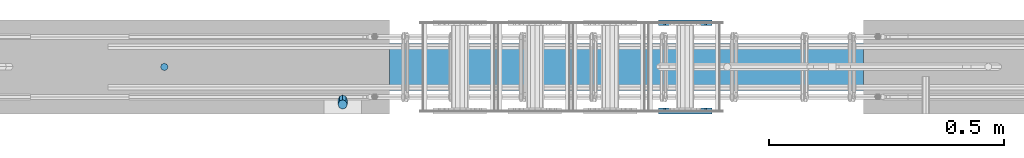
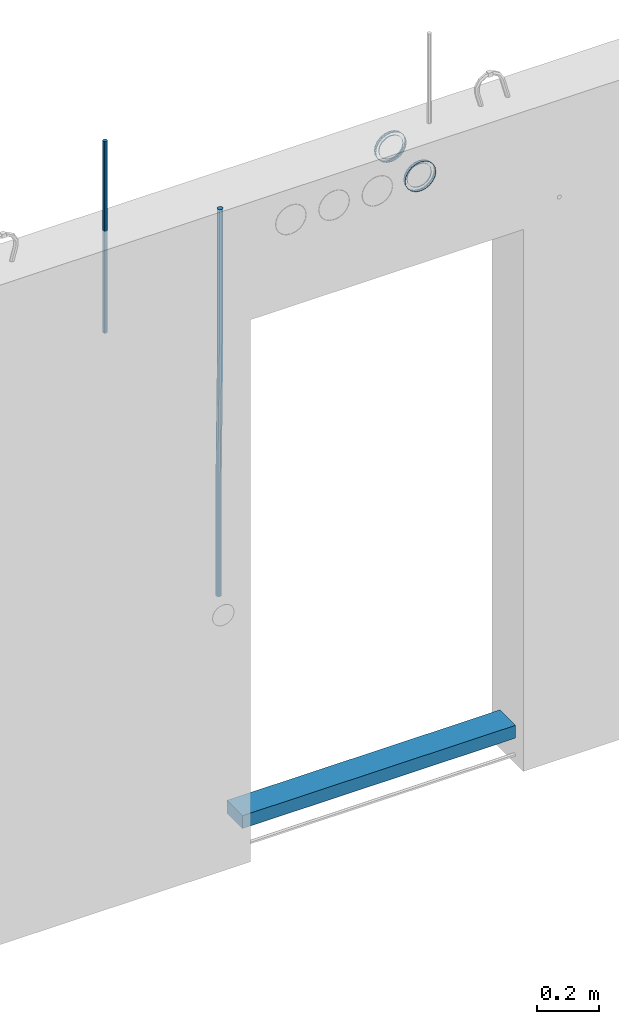
# One storey, part 1 of 11: 9 beams.
"""IFC2X3 building model written with IfcOpenShell, lengths in millimetres."""

from ifc_helpers import new_model, si_unit, frame, origin_with_axes, place, context, subcontext, project, spatial, faceted_brep, material, type_object, element, save


model = new_model("IFC2X3")

# Units and contexts
model_context = context("Model", 3, precision=1e-05, world=origin_with_axes())
body_context = subcontext(model_context, "Body", "Model", "MODEL_VIEW")
ifc_project = project(units=[si_unit("LENGTHUNIT", "METRE", prefix="MILLI"), si_unit("AREAUNIT", "SQUARE_METRE"), si_unit("VOLUMEUNIT", "CUBIC_METRE"), si_unit("MASSUNIT", "GRAM", prefix="KILO"), si_unit("TIMEUNIT", "SECOND"), si_unit("PLANEANGLEUNIT", "RADIAN"), si_unit("SOLIDANGLEUNIT", "STERADIAN"), si_unit("THERMODYNAMICTEMPERATUREUNIT", "DEGREE_CELSIUS"), si_unit("LUMINOUSINTENSITYUNIT", "LUMEN")], contexts=[model_context])

# Site, building, storey
site_placement = place(None, origin_with_axes())
site = spatial("IfcSite", under=ifc_project, at=site_placement, CompositionType="ELEMENT")
building_placement = place(site_placement, origin_with_axes())
building = spatial("IfcBuilding", under=site, at=building_placement, Name="Undefined", CompositionType="ELEMENT")
storey_placement = place(building_placement, origin_with_axes())
storey = spatial("IfcBuildingStorey", under=building, at=storey_placement, Name="Undefined", CompositionType="ELEMENT", Elevation=0.0)

# Beams
ifc_material_1 = material(Name="REBAR/A500HW")
beam_type_1 = type_object("IfcBeamType", Name="D16", PredefinedType="NOTDEFINED")
beam_1_placement = place(storey_placement, frame((869.990014805153, -99.9999587567853, 2805.000000041), z_axis=(-1.0, 0.0, 0.0), x_axis=(0.0, 0.0, -1.0)))
element("IfcBeam", 1, at=beam_1_placement, inside=storey, type_object=beam_type_1, material=ifc_material_1, ObjectType="D16", context=body_context, shape_type="Brep", body=[
    faceted_brep([(0.0, -8.0, 0.0), (0.0, -5.65685424949238, -5.65685424949243), (750.0, -5.65685424949238, -5.65685424949243), (750.0, -8.0, 0.0), (0.0, 0.0, -8.0), (750.0, 0.0, -8.0), (0.0, 5.65685424949238, -5.65685424949243), (750.0, 5.65685424949238, -5.65685424949243), (0.0, 8.0, 0.0), (750.0, 8.0, 0.0), (0.0, 5.65685424949238, 5.65685424949243), (750.0, 5.65685424949238, 5.65685424949243), (0.0, 0.0, 8.0), (750.0, 0.0, 8.0), (0.0, -5.65685424949238, 5.65685424949243), (750.0, -5.65685424949238, 5.65685424949243)], [[[0, 1, 2, 3]], [[1, 4, 5, 2]], [[4, 6, 7, 5]], [[6, 8, 9, 7]], [[8, 10, 11, 9]], [[10, 12, 13, 11]], [[12, 14, 15, 13]], [[14, 0, 3, 15]], [[5, 7, 9, 11, 13, 15, 3, 2]], [[14, 12, 10, 8, 6, 4, 1, 0]]]),
])
ifc_material_2 = material(Name="TIMBER")
beam_type_2 = type_object("IfcBeamType", Name="50X100", PredefinedType="NOTDEFINED")
beam_2_placement = place(storey_placement, frame((1349.99888029706, -99.9999994195658, 4.10316260968102e-08), z_axis=(0.0, 0.0, 1.0), x_axis=(1.0, 0.0, 0.0)))
element("IfcBeam", 2, at=beam_2_placement, inside=storey, type_object=beam_type_2, material=ifc_material_2, ObjectType="50X100", context=body_context, shape_type="Brep", body=[
    faceted_brep([(0.0, 50.0, -25.0), (0.0, 50.0, 25.0), (1010.00203523022, 50.0, 25.0), (1010.00203523022, 50.0, -25.0), (0.0, -50.0, 25.0), (1010.00203523022, -50.0, 25.0), (0.0, -50.0, -25.0), (1010.00203523022, -50.0, -25.0)], [[[0, 1, 2, 3]], [[1, 4, 5, 2]], [[4, 6, 7, 5]], [[6, 0, 3, 7]], [[5, 7, 3, 2]], [[6, 4, 1, 0]]]),
])
ifc_material_3 = material(Name="STEEL/Steel_Undefined")
beam_type_3 = type_object("IfcBeamType", PredefinedType="NOTDEFINED")
beam_3_placement = place(storey_placement, frame((1979.98457749309, -5.08317012009296, 2335.01381840039), z_axis=(-1.0, 0.0, 0.0), x_axis=(0.0, 1.0, 0.0)))
element("IfcBeam", 3, at=beam_3_placement, inside=storey, type_object=beam_type_3, material=ifc_material_3, Name="K160", context=body_context, shape_type="Brep", body=[
    faceted_brep([(0.0, -56.0, 0.0), (0.0, -53.2591649125284, 17.3049516849972), (5.0, -53.2591649125284, 17.3049516849972), (5.0, -56.0, 0.0), (0.0, -45.3049516849969, 32.9159741283786), (5.0, -45.3049516849969, 32.9159741283786), (0.0, -32.9159741283784, 45.3049516849972), (5.0, -32.9159741283784, 45.3049516849972), (0.0, -17.3049516849969, 53.2591649125286), (5.0, -17.3049516849969, 53.2591649125286), (0.0, 0.0, 56.0), (5.0, 0.0, 56.0), (0.0, 17.3049516849969, 53.2591649125286), (5.0, 17.3049516849969, 53.2591649125286), (0.0, 32.9159741283784, 45.3049516849972), (5.0, 32.9159741283784, 45.3049516849972), (0.0, 45.3049516849969, 32.9159741283786), (5.0, 45.3049516849969, 32.9159741283786), (0.0, 53.2591649125284, 17.3049516849972), (5.0, 53.2591649125284, 17.3049516849972), (0.0, 56.0, 0.0), (5.0, 56.0, 0.0), (0.0, 53.2591649125284, -17.3049516849972), (5.0, 53.2591649125284, -17.3049516849972), (0.0, 45.3049516849969, -32.9159741283786), (5.0, 45.3049516849969, -32.9159741283786), (0.0, 32.9159741283784, -45.3049516849972), (5.0, 32.9159741283784, -45.3049516849972), (0.0, 17.3049516849969, -53.2591649125286), (5.0, 17.3049516849969, -53.2591649125286), (0.0, 0.0, -56.0), (5.0, 0.0, -56.0), (0.0, -17.3049516849969, -53.2591649125286), (5.0, -17.3049516849969, -53.2591649125286), (0.0, -32.9159741283784, -45.3049516849972), (5.0, -32.9159741283784, -45.3049516849972), (0.0, -45.3049516849969, -32.9159741283786), (5.0, -45.3049516849969, -32.9159741283786), (0.0, -53.2591649125284, -17.3049516849972), (5.0, -53.2591649125284, -17.3049516849972), (0.0, -57.0, 0.0), (0.0, -54.2102214288238, -17.613968679372), (5.0, -54.2102214288238, -17.613968679372), (5.0, -57.0, 0.0), (0.0, -46.1139686793722, -33.503759380671), (5.0, -46.1139686793722, -33.503759380671), (0.0, -33.503759380671, -46.113968679372), (5.0, -33.503759380671, -46.113968679372), (0.0, -17.6139686793722, -54.2102214288238), (5.0, -17.6139686793722, -54.2102214288238), (0.0, 0.0, -57.0), (5.0, 0.0, -57.0), (0.0, 17.6139686793722, -54.2102214288238), (5.0, 17.6139686793722, -54.2102214288238), (0.0, 33.503759380671, -46.113968679372), (5.0, 33.503759380671, -46.113968679372), (0.0, 46.1139686793722, -33.503759380671), (5.0, 46.1139686793722, -33.503759380671), (0.0, 54.2102214288238, -17.613968679372), (5.0, 54.2102214288238, -17.613968679372), (0.0, 57.0, 0.0), (5.0, 57.0, 0.0), (0.0, 54.2102214288238, 17.613968679372), (5.0, 54.2102214288238, 17.613968679372), (0.0, 46.1139686793722, 33.503759380671), (5.0, 46.1139686793722, 33.503759380671), (0.0, 33.503759380671, 46.113968679372), (5.0, 33.503759380671, 46.113968679372), (0.0, 17.6139686793722, 54.2102214288238), (5.0, 17.6139686793722, 54.2102214288238), (0.0, 0.0, 57.0), (5.0, 0.0, 57.0), (0.0, -17.6139686793722, 54.2102214288238), (5.0, -17.6139686793722, 54.2102214288238), (0.0, -33.503759380671, 46.113968679372), (5.0, -33.503759380671, 46.113968679372), (0.0, -46.1139686793722, 33.503759380671), (5.0, -46.1139686793722, 33.503759380671), (0.0, -54.2102214288238, 17.613968679372), (5.0, -54.2102214288238, 17.613968679372)], [[[0, 1, 2, 3]], [[1, 4, 5, 2]], [[4, 6, 7, 5]], [[6, 8, 9, 7]], [[8, 10, 11, 9]], [[10, 12, 13, 11]], [[12, 14, 15, 13]], [[14, 16, 17, 15]], [[16, 18, 19, 17]], [[18, 20, 21, 19]], [[20, 22, 23, 21]], [[22, 24, 25, 23]], [[24, 26, 27, 25]], [[26, 28, 29, 27]], [[28, 30, 31, 29]], [[30, 32, 33, 31]], [[32, 34, 35, 33]], [[34, 36, 37, 35]], [[36, 38, 39, 37]], [[38, 0, 3, 39]], [[40, 41, 42, 43]], [[41, 44, 45, 42]], [[44, 46, 47, 45]], [[46, 48, 49, 47]], [[48, 50, 51, 49]], [[50, 52, 53, 51]], [[52, 54, 55, 53]], [[54, 56, 57, 55]], [[56, 58, 59, 57]], [[58, 60, 61, 59]], [[60, 62, 63, 61]], [[62, 64, 65, 63]], [[64, 66, 67, 65]], [[66, 68, 69, 67]], [[68, 70, 71, 69]], [[70, 72, 73, 71]], [[72, 74, 75, 73]], [[74, 76, 77, 75]], [[76, 78, 79, 77]], [[78, 40, 43, 79]], [[45, 47, 49, 51, 53, 55, 57, 59, 61, 63, 65, 67, 69, 71, 73, 75, 77, 79, 43, 42], [5, 7, 9, 11, 13, 15, 17, 19, 21, 23, 25, 27, 29, 31, 33, 35, 37, 39, 3, 2]], [[78, 76, 74, 72, 70, 68, 66, 64, 62, 60, 58, 56, 54, 52, 50, 48, 46, 44, 41, 40], [38, 36, 34, 32, 30, 28, 26, 24, 22, 20, 18, 16, 14, 12, 10, 8, 6, 4, 1, 0]]]),
])
beam_4_placement = place(storey_placement, frame((1979.98457749309, -200.083170120093, 2335.01381840039), z_axis=(-1.0, 0.0, 0.0), x_axis=(0.0, 1.0, 0.0)))
element("IfcBeam", 4, at=beam_4_placement, inside=storey, type_object=beam_type_3, material=ifc_material_3, context=body_context, shape_type="Brep", body=[
    faceted_brep([(0.0, -56.0, 0.0), (0.0, -53.2591649125284, 17.3049516849972), (5.0, -53.2591649125284, 17.3049516849972), (5.0, -56.0, 0.0), (0.0, -45.3049516849969, 32.9159741283786), (5.0, -45.3049516849969, 32.9159741283786), (0.0, -32.9159741283784, 45.3049516849972), (5.0, -32.9159741283784, 45.3049516849972), (0.0, -17.3049516849969, 53.2591649125286), (5.0, -17.3049516849969, 53.2591649125286), (0.0, 0.0, 56.0), (5.0, 0.0, 56.0), (0.0, 17.3049516849969, 53.2591649125286), (5.0, 17.3049516849969, 53.2591649125286), (0.0, 32.9159741283784, 45.3049516849972), (5.0, 32.9159741283784, 45.3049516849972), (0.0, 45.3049516849969, 32.9159741283786), (5.0, 45.3049516849969, 32.9159741283786), (0.0, 53.2591649125284, 17.3049516849972), (5.0, 53.2591649125284, 17.3049516849972), (0.0, 56.0, 0.0), (5.0, 56.0, 0.0), (0.0, 53.2591649125284, -17.3049516849972), (5.0, 53.2591649125284, -17.3049516849972), (0.0, 45.3049516849969, -32.9159741283786), (5.0, 45.3049516849969, -32.9159741283786), (0.0, 32.9159741283784, -45.3049516849972), (5.0, 32.9159741283784, -45.3049516849972), (0.0, 17.3049516849969, -53.2591649125286), (5.0, 17.3049516849969, -53.2591649125286), (0.0, 0.0, -56.0), (5.0, 0.0, -56.0), (0.0, -17.3049516849969, -53.2591649125286), (5.0, -17.3049516849969, -53.2591649125286), (0.0, -32.9159741283784, -45.3049516849972), (5.0, -32.9159741283784, -45.3049516849972), (0.0, -45.3049516849969, -32.9159741283786), (5.0, -45.3049516849969, -32.9159741283786), (0.0, -53.2591649125284, -17.3049516849972), (5.0, -53.2591649125284, -17.3049516849972), (0.0, -57.0, 0.0), (0.0, -54.2102214288238, -17.613968679372), (5.0, -54.2102214288238, -17.613968679372), (5.0, -57.0, 0.0), (0.0, -46.1139686793722, -33.503759380671), (5.0, -46.1139686793722, -33.503759380671), (0.0, -33.503759380671, -46.113968679372), (5.0, -33.503759380671, -46.113968679372), (0.0, -17.6139686793722, -54.2102214288238), (5.0, -17.6139686793722, -54.2102214288238), (0.0, 0.0, -57.0), (5.0, 0.0, -57.0), (0.0, 17.6139686793722, -54.2102214288238), (5.0, 17.6139686793722, -54.2102214288238), (0.0, 33.503759380671, -46.113968679372), (5.0, 33.503759380671, -46.113968679372), (0.0, 46.1139686793722, -33.503759380671), (5.0, 46.1139686793722, -33.503759380671), (0.0, 54.2102214288238, -17.613968679372), (5.0, 54.2102214288238, -17.613968679372), (0.0, 57.0, 0.0), (5.0, 57.0, 0.0), (0.0, 54.2102214288238, 17.613968679372), (5.0, 54.2102214288238, 17.613968679372), (0.0, 46.1139686793722, 33.503759380671), (5.0, 46.1139686793722, 33.503759380671), (0.0, 33.503759380671, 46.113968679372), (5.0, 33.503759380671, 46.113968679372), (0.0, 17.6139686793722, 54.2102214288238), (5.0, 17.6139686793722, 54.2102214288238), (0.0, 0.0, 57.0), (5.0, 0.0, 57.0), (0.0, -17.6139686793722, 54.2102214288238), (5.0, -17.6139686793722, 54.2102214288238), (0.0, -33.503759380671, 46.113968679372), (5.0, -33.503759380671, 46.113968679372), (0.0, -46.1139686793722, 33.503759380671), (5.0, -46.1139686793722, 33.503759380671), (0.0, -54.2102214288238, 17.613968679372), (5.0, -54.2102214288238, 17.613968679372)], [[[0, 1, 2, 3]], [[1, 4, 5, 2]], [[4, 6, 7, 5]], [[6, 8, 9, 7]], [[8, 10, 11, 9]], [[10, 12, 13, 11]], [[12, 14, 15, 13]], [[14, 16, 17, 15]], [[16, 18, 19, 17]], [[18, 20, 21, 19]], [[20, 22, 23, 21]], [[22, 24, 25, 23]], [[24, 26, 27, 25]], [[26, 28, 29, 27]], [[28, 30, 31, 29]], [[30, 32, 33, 31]], [[32, 34, 35, 33]], [[34, 36, 37, 35]], [[36, 38, 39, 37]], [[38, 0, 3, 39]], [[40, 41, 42, 43]], [[41, 44, 45, 42]], [[44, 46, 47, 45]], [[46, 48, 49, 47]], [[48, 50, 51, 49]], [[50, 52, 53, 51]], [[52, 54, 55, 53]], [[54, 56, 57, 55]], [[56, 58, 59, 57]], [[58, 60, 61, 59]], [[60, 62, 63, 61]], [[62, 64, 65, 63]], [[64, 66, 67, 65]], [[66, 68, 69, 67]], [[68, 70, 71, 69]], [[70, 72, 73, 71]], [[72, 74, 75, 73]], [[74, 76, 77, 75]], [[76, 78, 79, 77]], [[78, 40, 43, 79]], [[45, 47, 49, 51, 53, 55, 57, 59, 61, 63, 65, 67, 69, 71, 73, 75, 77, 79, 43, 42], [5, 7, 9, 11, 13, 15, 17, 19, 21, 23, 25, 27, 29, 31, 33, 35, 37, 39, 3, 2]], [[78, 76, 74, 72, 70, 68, 66, 64, 62, 60, 58, 56, 54, 52, 50, 48, 46, 44, 41, 40], [38, 36, 34, 32, 30, 28, 26, 24, 22, 20, 18, 16, 14, 12, 10, 8, 6, 4, 1, 0]]]),
])
beam_5_placement = place(storey_placement, frame((1979.98457749309, -12.083170120093, 2335.01381840039), z_axis=(-1.0, 0.0, 0.0), x_axis=(0.0, 1.0, 0.0)))
element("IfcBeam", 5, at=beam_5_placement, inside=storey, type_object=beam_type_3, material=ifc_material_3, context=body_context, shape_type="Brep", body=[
    faceted_brep([(0.0, -56.0, 0.0), (0.0, -53.2591649125284, 17.3049516849972), (5.0, -53.2591649125284, 17.3049516849972), (5.0, -56.0, 0.0), (0.0, -45.3049516849969, 32.9159741283786), (5.0, -45.3049516849969, 32.9159741283786), (0.0, -32.9159741283784, 45.3049516849972), (5.0, -32.9159741283784, 45.3049516849972), (0.0, -17.3049516849969, 53.2591649125286), (5.0, -17.3049516849969, 53.2591649125286), (0.0, 0.0, 56.0), (5.0, 0.0, 56.0), (0.0, 17.3049516849969, 53.2591649125286), (5.0, 17.3049516849969, 53.2591649125286), (0.0, 32.9159741283784, 45.3049516849972), (5.0, 32.9159741283784, 45.3049516849972), (0.0, 45.3049516849969, 32.9159741283786), (5.0, 45.3049516849969, 32.9159741283786), (0.0, 53.2591649125284, 17.3049516849972), (5.0, 53.2591649125284, 17.3049516849972), (0.0, 56.0, 0.0), (5.0, 56.0, 0.0), (0.0, 53.2591649125284, -17.3049516849972), (5.0, 53.2591649125284, -17.3049516849972), (0.0, 45.3049516849969, -32.9159741283786), (5.0, 45.3049516849969, -32.9159741283786), (0.0, 32.9159741283784, -45.3049516849972), (5.0, 32.9159741283784, -45.3049516849972), (0.0, 17.3049516849969, -53.2591649125286), (5.0, 17.3049516849969, -53.2591649125286), (0.0, 0.0, -56.0), (5.0, 0.0, -56.0), (0.0, -17.3049516849969, -53.2591649125286), (5.0, -17.3049516849969, -53.2591649125286), (0.0, -32.9159741283784, -45.3049516849972), (5.0, -32.9159741283784, -45.3049516849972), (0.0, -45.3049516849969, -32.9159741283786), (5.0, -45.3049516849969, -32.9159741283786), (0.0, -53.2591649125284, -17.3049516849972), (5.0, -53.2591649125284, -17.3049516849972), (0.0, -57.0, 0.0), (0.0, -54.2102214288238, -17.613968679372), (5.0, -54.2102214288238, -17.613968679372), (5.0, -57.0, 0.0), (0.0, -46.1139686793722, -33.503759380671), (5.0, -46.1139686793722, -33.503759380671), (0.0, -33.503759380671, -46.113968679372), (5.0, -33.503759380671, -46.113968679372), (0.0, -17.6139686793722, -54.2102214288238), (5.0, -17.6139686793722, -54.2102214288238), (0.0, 0.0, -57.0), (5.0, 0.0, -57.0), (0.0, 17.6139686793722, -54.2102214288238), (5.0, 17.6139686793722, -54.2102214288238), (0.0, 33.503759380671, -46.113968679372), (5.0, 33.503759380671, -46.113968679372), (0.0, 46.1139686793722, -33.503759380671), (5.0, 46.1139686793722, -33.503759380671), (0.0, 54.2102214288238, -17.613968679372), (5.0, 54.2102214288238, -17.613968679372), (0.0, 57.0, 0.0), (5.0, 57.0, 0.0), (0.0, 54.2102214288238, 17.613968679372), (5.0, 54.2102214288238, 17.613968679372), (0.0, 46.1139686793722, 33.503759380671), (5.0, 46.1139686793722, 33.503759380671), (0.0, 33.503759380671, 46.113968679372), (5.0, 33.503759380671, 46.113968679372), (0.0, 17.6139686793722, 54.2102214288238), (5.0, 17.6139686793722, 54.2102214288238), (0.0, 0.0, 57.0), (5.0, 0.0, 57.0), (0.0, -17.6139686793722, 54.2102214288238), (5.0, -17.6139686793722, 54.2102214288238), (0.0, -33.503759380671, 46.113968679372), (5.0, -33.503759380671, 46.113968679372), (0.0, -46.1139686793722, 33.503759380671), (5.0, -46.1139686793722, 33.503759380671), (0.0, -54.2102214288238, 17.613968679372), (5.0, -54.2102214288238, 17.613968679372)], [[[0, 1, 2, 3]], [[1, 4, 5, 2]], [[4, 6, 7, 5]], [[6, 8, 9, 7]], [[8, 10, 11, 9]], [[10, 12, 13, 11]], [[12, 14, 15, 13]], [[14, 16, 17, 15]], [[16, 18, 19, 17]], [[18, 20, 21, 19]], [[20, 22, 23, 21]], [[22, 24, 25, 23]], [[24, 26, 27, 25]], [[26, 28, 29, 27]], [[28, 30, 31, 29]], [[30, 32, 33, 31]], [[32, 34, 35, 33]], [[34, 36, 37, 35]], [[36, 38, 39, 37]], [[38, 0, 3, 39]], [[40, 41, 42, 43]], [[41, 44, 45, 42]], [[44, 46, 47, 45]], [[46, 48, 49, 47]], [[48, 50, 51, 49]], [[50, 52, 53, 51]], [[52, 54, 55, 53]], [[54, 56, 57, 55]], [[56, 58, 59, 57]], [[58, 60, 61, 59]], [[60, 62, 63, 61]], [[62, 64, 65, 63]], [[64, 66, 67, 65]], [[66, 68, 69, 67]], [[68, 70, 71, 69]], [[70, 72, 73, 71]], [[72, 74, 75, 73]], [[74, 76, 77, 75]], [[76, 78, 79, 77]], [[78, 40, 43, 79]], [[45, 47, 49, 51, 53, 55, 57, 59, 61, 63, 65, 67, 69, 71, 73, 75, 77, 79, 43, 42], [5, 7, 9, 11, 13, 15, 17, 19, 21, 23, 25, 27, 29, 31, 33, 35, 37, 39, 3, 2]], [[78, 76, 74, 72, 70, 68, 66, 64, 62, 60, 58, 56, 54, 52, 50, 48, 46, 44, 41, 40], [38, 36, 34, 32, 30, 28, 26, 24, 22, 20, 18, 16, 14, 12, 10, 8, 6, 4, 1, 0]]]),
])
beam_6_placement = place(storey_placement, frame((1979.98457749309, -188.083170120093, 2335.01381840039), z_axis=(-1.0, 0.0, 0.0), x_axis=(0.0, -1.0, 0.0)))
element("IfcBeam", 6, at=beam_6_placement, inside=storey, type_object=beam_type_3, material=ifc_material_3, context=body_context, shape_type="Brep", body=[
    faceted_brep([(0.0, -56.0, 0.0), (0.0, -53.2591649125284, 17.3049516849972), (5.0, -53.2591649125284, 17.3049516849972), (5.0, -56.0, 0.0), (0.0, -45.3049516849969, 32.9159741283786), (5.0, -45.3049516849969, 32.9159741283786), (0.0, -32.9159741283784, 45.3049516849972), (5.0, -32.9159741283784, 45.3049516849972), (0.0, -17.3049516849969, 53.2591649125286), (5.0, -17.3049516849969, 53.2591649125286), (0.0, 0.0, 56.0), (5.0, 0.0, 56.0), (0.0, 17.3049516849969, 53.2591649125286), (5.0, 17.3049516849969, 53.2591649125286), (0.0, 32.9159741283784, 45.3049516849972), (5.0, 32.9159741283784, 45.3049516849972), (0.0, 45.3049516849969, 32.9159741283786), (5.0, 45.3049516849969, 32.9159741283786), (0.0, 53.2591649125284, 17.3049516849972), (5.0, 53.2591649125284, 17.3049516849972), (0.0, 56.0, 0.0), (5.0, 56.0, 0.0), (0.0, 53.2591649125284, -17.3049516849972), (5.0, 53.2591649125284, -17.3049516849972), (0.0, 45.3049516849969, -32.9159741283786), (5.0, 45.3049516849969, -32.9159741283786), (0.0, 32.9159741283784, -45.3049516849972), (5.0, 32.9159741283784, -45.3049516849972), (0.0, 17.3049516849969, -53.2591649125286), (5.0, 17.3049516849969, -53.2591649125286), (0.0, 0.0, -56.0), (5.0, 0.0, -56.0), (0.0, -17.3049516849969, -53.2591649125286), (5.0, -17.3049516849969, -53.2591649125286), (0.0, -32.9159741283784, -45.3049516849972), (5.0, -32.9159741283784, -45.3049516849972), (0.0, -45.3049516849969, -32.9159741283786), (5.0, -45.3049516849969, -32.9159741283786), (0.0, -53.2591649125284, -17.3049516849972), (5.0, -53.2591649125284, -17.3049516849972), (0.0, -57.0, 0.0), (0.0, -54.2102214288238, -17.613968679372), (5.0, -54.2102214288238, -17.613968679372), (5.0, -57.0, 0.0), (0.0, -46.1139686793722, -33.503759380671), (5.0, -46.1139686793722, -33.503759380671), (0.0, -33.503759380671, -46.113968679372), (5.0, -33.503759380671, -46.113968679372), (0.0, -17.6139686793722, -54.2102214288238), (5.0, -17.6139686793722, -54.2102214288238), (0.0, 0.0, -57.0), (5.0, 0.0, -57.0), (0.0, 17.6139686793722, -54.2102214288238), (5.0, 17.6139686793722, -54.2102214288238), (0.0, 33.503759380671, -46.113968679372), (5.0, 33.503759380671, -46.113968679372), (0.0, 46.1139686793722, -33.503759380671), (5.0, 46.1139686793722, -33.503759380671), (0.0, 54.2102214288238, -17.613968679372), (5.0, 54.2102214288238, -17.613968679372), (0.0, 57.0, 0.0), (5.0, 57.0, 0.0), (0.0, 54.2102214288238, 17.613968679372), (5.0, 54.2102214288238, 17.613968679372), (0.0, 46.1139686793722, 33.503759380671), (5.0, 46.1139686793722, 33.503759380671), (0.0, 33.503759380671, 46.113968679372), (5.0, 33.503759380671, 46.113968679372), (0.0, 17.6139686793722, 54.2102214288238), (5.0, 17.6139686793722, 54.2102214288238), (0.0, 0.0, 57.0), (5.0, 0.0, 57.0), (0.0, -17.6139686793722, 54.2102214288238), (5.0, -17.6139686793722, 54.2102214288238), (0.0, -33.503759380671, 46.113968679372), (5.0, -33.503759380671, 46.113968679372), (0.0, -46.1139686793722, 33.503759380671), (5.0, -46.1139686793722, 33.503759380671), (0.0, -54.2102214288238, 17.613968679372), (5.0, -54.2102214288238, 17.613968679372)], [[[0, 1, 2, 3]], [[1, 4, 5, 2]], [[4, 6, 7, 5]], [[6, 8, 9, 7]], [[8, 10, 11, 9]], [[10, 12, 13, 11]], [[12, 14, 15, 13]], [[14, 16, 17, 15]], [[16, 18, 19, 17]], [[18, 20, 21, 19]], [[20, 22, 23, 21]], [[22, 24, 25, 23]], [[24, 26, 27, 25]], [[26, 28, 29, 27]], [[28, 30, 31, 29]], [[30, 32, 33, 31]], [[32, 34, 35, 33]], [[34, 36, 37, 35]], [[36, 38, 39, 37]], [[38, 0, 3, 39]], [[40, 41, 42, 43]], [[41, 44, 45, 42]], [[44, 46, 47, 45]], [[46, 48, 49, 47]], [[48, 50, 51, 49]], [[50, 52, 53, 51]], [[52, 54, 55, 53]], [[54, 56, 57, 55]], [[56, 58, 59, 57]], [[58, 60, 61, 59]], [[60, 62, 63, 61]], [[62, 64, 65, 63]], [[64, 66, 67, 65]], [[66, 68, 69, 67]], [[68, 70, 71, 69]], [[70, 72, 73, 71]], [[72, 74, 75, 73]], [[74, 76, 77, 75]], [[76, 78, 79, 77]], [[78, 40, 43, 79]], [[45, 47, 49, 51, 53, 55, 57, 59, 61, 63, 65, 67, 69, 71, 73, 75, 77, 79, 43, 42], [5, 7, 9, 11, 13, 15, 17, 19, 21, 23, 25, 27, 29, 31, 33, 35, 37, 39, 3, 2]], [[78, 76, 74, 72, 70, 68, 66, 64, 62, 60, 58, 56, 54, 52, 50, 48, 46, 44, 41, 40], [38, 36, 34, 32, 30, 28, 26, 24, 22, 20, 18, 16, 14, 12, 10, 8, 6, 4, 1, 0]]]),
])
beam_type_4 = type_object("IfcBeamType", PredefinedType="NOTDEFINED")
beam_7_placement = place(storey_placement, frame((1979.98457749309, -12.083170120093, 2335.01381840039), z_axis=(-1.0, 0.0, 0.0), x_axis=(0.0, 1.0, 0.0)))
element("IfcBeam", 7, at=beam_7_placement, inside=storey, type_object=beam_type_4, material=ifc_material_3, context=body_context, shape_type="Brep", body=[
    faceted_brep([(0.0, -44.5, 0.0), (0.0, -41.1126391967523, 17.0294127402465), (5.0, -41.1126391967523, 17.0294127402465), (5.0, -44.5, 0.0), (0.0, -31.4662517628012, 31.4662517628014), (5.0, -31.4662517628012, 31.4662517628014), (0.0, -17.0294127402467, 41.1126391967523), (5.0, -17.0294127402467, 41.1126391967523), (0.0, 0.0, 44.5), (5.0, 0.0, 44.5), (0.0, 17.0294127402467, 41.1126391967523), (5.0, 17.0294127402467, 41.1126391967523), (0.0, 31.4662517628012, 31.4662517628014), (5.0, 31.4662517628012, 31.4662517628014), (0.0, 41.1126391967523, 17.0294127402465), (5.0, 41.1126391967523, 17.0294127402465), (0.0, 44.5, 0.0), (5.0, 44.5, 0.0), (0.0, 41.1126391967523, -17.0294127402465), (5.0, 41.1126391967523, -17.0294127402465), (0.0, 31.4662517628012, -31.4662517628014), (5.0, 31.4662517628012, -31.4662517628014), (0.0, 17.0294127402467, -41.1126391967523), (5.0, 17.0294127402467, -41.1126391967523), (0.0, 0.0, -44.5), (5.0, 0.0, -44.5), (0.0, -17.0294127402467, -41.1126391967523), (5.0, -17.0294127402467, -41.1126391967523), (0.0, -31.4662517628012, -31.4662517628014), (5.0, -31.4662517628012, -31.4662517628014), (0.0, -41.1126391967523, -17.0294127402465), (5.0, -41.1126391967523, -17.0294127402465), (0.0, -45.5, 0.0), (0.0, -42.0365187292637, -17.4120961726117), (5.0, -42.0365187292637, -17.4120961726117), (5.0, -45.5, 0.0), (0.0, -32.1733585439879, -32.1733585439879), (5.0, -32.1733585439879, -32.1733585439879), (0.0, -17.4120961726117, -42.0365187292634), (5.0, -17.4120961726117, -42.0365187292634), (0.0, 0.0, -45.5), (5.0, 0.0, -45.5), (0.0, 17.4120961726117, -42.0365187292634), (5.0, 17.4120961726117, -42.0365187292634), (0.0, 32.1733585439879, -32.1733585439879), (5.0, 32.1733585439879, -32.1733585439879), (0.0, 42.0365187292637, -17.4120961726117), (5.0, 42.0365187292637, -17.4120961726117), (0.0, 45.5, 0.0), (5.0, 45.5, 0.0), (0.0, 42.0365187292637, 17.4120961726117), (5.0, 42.0365187292637, 17.4120961726117), (0.0, 32.1733585439879, 32.1733585439879), (5.0, 32.1733585439879, 32.1733585439879), (0.0, 17.4120961726117, 42.0365187292634), (5.0, 17.4120961726117, 42.0365187292634), (0.0, 0.0, 45.5), (5.0, 0.0, 45.5), (0.0, -17.4120961726117, 42.0365187292634), (5.0, -17.4120961726117, 42.0365187292634), (0.0, -32.1733585439879, 32.1733585439879), (5.0, -32.1733585439879, 32.1733585439879), (0.0, -42.0365187292637, 17.4120961726117), (5.0, -42.0365187292637, 17.4120961726117)], [[[0, 1, 2, 3]], [[1, 4, 5, 2]], [[4, 6, 7, 5]], [[6, 8, 9, 7]], [[8, 10, 11, 9]], [[10, 12, 13, 11]], [[12, 14, 15, 13]], [[14, 16, 17, 15]], [[16, 18, 19, 17]], [[18, 20, 21, 19]], [[20, 22, 23, 21]], [[22, 24, 25, 23]], [[24, 26, 27, 25]], [[26, 28, 29, 27]], [[28, 30, 31, 29]], [[30, 0, 3, 31]], [[32, 33, 34, 35]], [[33, 36, 37, 34]], [[36, 38, 39, 37]], [[38, 40, 41, 39]], [[40, 42, 43, 41]], [[42, 44, 45, 43]], [[44, 46, 47, 45]], [[46, 48, 49, 47]], [[48, 50, 51, 49]], [[50, 52, 53, 51]], [[52, 54, 55, 53]], [[54, 56, 57, 55]], [[56, 58, 59, 57]], [[58, 60, 61, 59]], [[60, 62, 63, 61]], [[62, 32, 35, 63]], [[37, 39, 41, 43, 45, 47, 49, 51, 53, 55, 57, 59, 61, 63, 35, 34], [5, 7, 9, 11, 13, 15, 17, 19, 21, 23, 25, 27, 29, 31, 3, 2]], [[62, 60, 58, 56, 54, 52, 50, 48, 46, 44, 42, 40, 38, 36, 33, 32], [30, 28, 26, 24, 22, 20, 18, 16, 14, 12, 10, 8, 6, 4, 1, 0]]]),
])
beam_8_placement = place(storey_placement, frame((1979.98457749309, -188.083170120093, 2335.01381840039), z_axis=(-1.0, 0.0, 0.0), x_axis=(0.0, -1.0, 0.0)))
element("IfcBeam", 8, at=beam_8_placement, inside=storey, type_object=beam_type_4, material=ifc_material_3, context=body_context, shape_type="Brep", body=[
    faceted_brep([(0.0, -44.5, 0.0), (0.0, -41.1126391967523, 17.0294127402465), (5.0, -41.1126391967523, 17.0294127402465), (5.0, -44.5, 0.0), (0.0, -31.4662517628012, 31.4662517628014), (5.0, -31.4662517628012, 31.4662517628014), (0.0, -17.0294127402467, 41.1126391967523), (5.0, -17.0294127402467, 41.1126391967523), (0.0, 0.0, 44.5), (5.0, 0.0, 44.5), (0.0, 17.0294127402467, 41.1126391967523), (5.0, 17.0294127402467, 41.1126391967523), (0.0, 31.4662517628012, 31.4662517628014), (5.0, 31.4662517628012, 31.4662517628014), (0.0, 41.1126391967523, 17.0294127402465), (5.0, 41.1126391967523, 17.0294127402465), (0.0, 44.5, 0.0), (5.0, 44.5, 0.0), (0.0, 41.1126391967523, -17.0294127402465), (5.0, 41.1126391967523, -17.0294127402465), (0.0, 31.4662517628012, -31.4662517628014), (5.0, 31.4662517628012, -31.4662517628014), (0.0, 17.0294127402467, -41.1126391967523), (5.0, 17.0294127402467, -41.1126391967523), (0.0, 0.0, -44.5), (5.0, 0.0, -44.5), (0.0, -17.0294127402467, -41.1126391967523), (5.0, -17.0294127402467, -41.1126391967523), (0.0, -31.4662517628012, -31.4662517628014), (5.0, -31.4662517628012, -31.4662517628014), (0.0, -41.1126391967523, -17.0294127402465), (5.0, -41.1126391967523, -17.0294127402465), (0.0, -45.5, 0.0), (0.0, -42.0365187292637, -17.4120961726117), (5.0, -42.0365187292637, -17.4120961726117), (5.0, -45.5, 0.0), (0.0, -32.1733585439879, -32.1733585439879), (5.0, -32.1733585439879, -32.1733585439879), (0.0, -17.4120961726117, -42.0365187292634), (5.0, -17.4120961726117, -42.0365187292634), (0.0, 0.0, -45.5), (5.0, 0.0, -45.5), (0.0, 17.4120961726117, -42.0365187292634), (5.0, 17.4120961726117, -42.0365187292634), (0.0, 32.1733585439879, -32.1733585439879), (5.0, 32.1733585439879, -32.1733585439879), (0.0, 42.0365187292637, -17.4120961726117), (5.0, 42.0365187292637, -17.4120961726117), (0.0, 45.5, 0.0), (5.0, 45.5, 0.0), (0.0, 42.0365187292637, 17.4120961726117), (5.0, 42.0365187292637, 17.4120961726117), (0.0, 32.1733585439879, 32.1733585439879), (5.0, 32.1733585439879, 32.1733585439879), (0.0, 17.4120961726117, 42.0365187292634), (5.0, 17.4120961726117, 42.0365187292634), (0.0, 0.0, 45.5), (5.0, 0.0, 45.5), (0.0, -17.4120961726117, 42.0365187292634), (5.0, -17.4120961726117, 42.0365187292634), (0.0, -32.1733585439879, 32.1733585439879), (5.0, -32.1733585439879, 32.1733585439879), (0.0, -42.0365187292637, 17.4120961726117), (5.0, -42.0365187292637, 17.4120961726117)], [[[0, 1, 2, 3]], [[1, 4, 5, 2]], [[4, 6, 7, 5]], [[6, 8, 9, 7]], [[8, 10, 11, 9]], [[10, 12, 13, 11]], [[12, 14, 15, 13]], [[14, 16, 17, 15]], [[16, 18, 19, 17]], [[18, 20, 21, 19]], [[20, 22, 23, 21]], [[22, 24, 25, 23]], [[24, 26, 27, 25]], [[26, 28, 29, 27]], [[28, 30, 31, 29]], [[30, 0, 3, 31]], [[32, 33, 34, 35]], [[33, 36, 37, 34]], [[36, 38, 39, 37]], [[38, 40, 41, 39]], [[40, 42, 43, 41]], [[42, 44, 45, 43]], [[44, 46, 47, 45]], [[46, 48, 49, 47]], [[48, 50, 51, 49]], [[50, 52, 53, 51]], [[52, 54, 55, 53]], [[54, 56, 57, 55]], [[56, 58, 59, 57]], [[58, 60, 61, 59]], [[60, 62, 63, 61]], [[62, 32, 35, 63]], [[37, 39, 41, 43, 45, 47, 49, 51, 53, 55, 57, 59, 61, 63, 35, 34], [5, 7, 9, 11, 13, 15, 17, 19, 21, 23, 25, 27, 29, 31, 3, 2]], [[62, 60, 58, 56, 54, 52, 50, 48, 46, 44, 42, 40, 38, 36, 33, 32], [30, 28, 26, 24, 22, 20, 18, 16, 14, 12, 10, 8, 6, 4, 1, 0]]]),
])
ifc_material_4 = material()
beam_type_5 = type_object("IfcBeamType", Name="D20", PredefinedType="NOTDEFINED")
beam_9_placement = place(storey_placement, frame((1249.99888029706, -169.999999419566, 935.00173393611), z_axis=(1.0, 0.0, 0.0), x_axis=(0.0, 0.0, 1.0)))
element("IfcBeam", 9, at=beam_9_placement, inside=storey, type_object=beam_type_5, material=ifc_material_4, ObjectType="D20", context=body_context, shape_type="Brep", body=[
    faceted_brep([(0.0, -10.0, 0.0), (0.0, -7.07106781186548, -7.07106781186553), (466.071148400053, -7.07106781186548, -7.07106781186553), (466.071148400053, -10.0, 0.0), (0.0, 0.0, -10.0), (466.071148400053, 0.0, -10.0), (0.0, 7.07106781186548, -7.07106781186553), (466.071148400053, 7.07106781186548, -7.07106781186553), (0.0, 10.0, 0.0), (466.071148400053, 10.0, 0.0), (0.0, 7.07106781186548, 7.07106781186553), (466.071148400053, 7.07106781186548, 7.07106781186553), (0.0, 0.0, 10.0), (466.071148400053, 0.0, 10.0), (0.0, -7.07106781186548, 7.07106781186553), (466.071148400053, -7.07106781186548, 7.07106781186553), (466.733201076602, -7.07106781186548, -7.07106781186553), (466.761004920259, -10.0, 0.0), (466.666076660156, 0.0, -10.0), (466.598952243711, 7.07106781186548, -7.07106781186553), (466.571148400053, 10.0, 0.0), (466.598952243711, 7.07106781186548, 7.07106781186553), (466.666076660156, 0.0, 10.0), (466.733201076602, -7.07106781186548, 7.07106781186553), (467.395134443808, -7.05849944271202, -7.07106781186553), (467.450737120559, -9.98690380431043, 0.0), (467.260897707493, 0.0112940831714354, -10.0), (467.126660971177, 7.08108760905486, -7.07106781186553), (467.071058294427, 10.0094919706533, 0.0), (467.126660971177, 7.08108760905486, 7.07106781186553), (467.260897707493, 0.0112940831714354, 10.0), (467.395134443808, -7.05849944271202, 7.07106781186553), (992.871569009291, 2.91891239094514, -7.07106781186553), (992.927171686042, -0.00949197065330054, 0.0), (992.737332272976, 9.98870591682856, -10.0), (992.60309553666, 17.058499442712, -7.07106781186553), (992.54749285991, 19.9869038043105, 0.0), (992.60309553666, 17.058499442712, 7.07106781186553), (992.737332272976, 9.98870591682856, 10.0), (992.871569009291, 2.91891239094514, 7.07106781186553), (993.399277736758, 2.92893218813452, -7.07106781186553), (993.427081580416, 0.0, 0.0), (993.332153320313, 10.0, -10.0), (993.265028903867, 17.0710678118655, -7.07106781186553), (993.237225060209, 20.0, 0.0), (993.265028903867, 17.0710678118655, 7.07106781186553), (993.332153320313, 10.0, 10.0), (993.399277736758, 2.92893218813452, 7.07106781186553), (993.927081580416, 2.92893218813452, -7.07106781186553), (993.927081580416, 0.0, 0.0), (993.927081580416, 10.0, -10.0), (993.927081580416, 17.0710678118655, -7.07106781186553), (993.927081580416, 20.0, 0.0), (993.927081580416, 17.0710678118655, 7.07106781186553), (993.927081580416, 10.0, 10.0), (993.927081580416, 2.92893218813452, 7.07106781186553), (1519.99829101563, 2.92893218813452, -7.07106781186553), (1519.99829101563, 0.0, 0.0), (1519.99829101563, 10.0, -10.0), (1519.99829101563, 17.0710678118655, -7.07106781186553), (1519.99829101563, 20.0, 0.0), (1519.99829101563, 17.0710678118655, 7.07106781186553), (1519.99829101563, 10.0, 10.0), (1519.99829101563, 2.92893218813452, 7.07106781186553)], [[[0, 1, 2, 3]], [[1, 4, 5, 2]], [[4, 6, 7, 5]], [[6, 8, 9, 7]], [[8, 10, 11, 9]], [[10, 12, 13, 11]], [[12, 14, 15, 13]], [[14, 0, 3, 15]], [[14, 12, 10, 8, 6, 4, 1, 0]], [[3, 2, 16, 17]], [[2, 5, 18, 16]], [[5, 7, 19, 18]], [[7, 9, 20, 19]], [[9, 11, 21, 20]], [[11, 13, 22, 21]], [[13, 15, 23, 22]], [[15, 3, 17, 23]], [[17, 16, 24, 25]], [[16, 18, 26, 24]], [[18, 19, 27, 26]], [[19, 20, 28, 27]], [[20, 21, 29, 28]], [[21, 22, 30, 29]], [[22, 23, 31, 30]], [[23, 17, 25, 31]], [[25, 24, 32, 33]], [[24, 26, 34, 32]], [[26, 27, 35, 34]], [[27, 28, 36, 35]], [[28, 29, 37, 36]], [[29, 30, 38, 37]], [[30, 31, 39, 38]], [[31, 25, 33, 39]], [[33, 32, 40, 41]], [[32, 34, 42, 40]], [[34, 35, 43, 42]], [[35, 36, 44, 43]], [[36, 37, 45, 44]], [[37, 38, 46, 45]], [[38, 39, 47, 46]], [[39, 33, 41, 47]], [[41, 40, 48, 49]], [[40, 42, 50, 48]], [[42, 43, 51, 50]], [[43, 44, 52, 51]], [[44, 45, 53, 52]], [[45, 46, 54, 53]], [[46, 47, 55, 54]], [[47, 41, 49, 55]], [[49, 48, 56, 57]], [[48, 50, 58, 56]], [[50, 51, 59, 58]], [[51, 52, 60, 59]], [[52, 53, 61, 60]], [[53, 54, 62, 61]], [[54, 55, 63, 62]], [[55, 49, 57, 63]], [[58, 59, 60, 61, 62, 63, 57, 56]]]),
])

save(model, "model.ifc")
